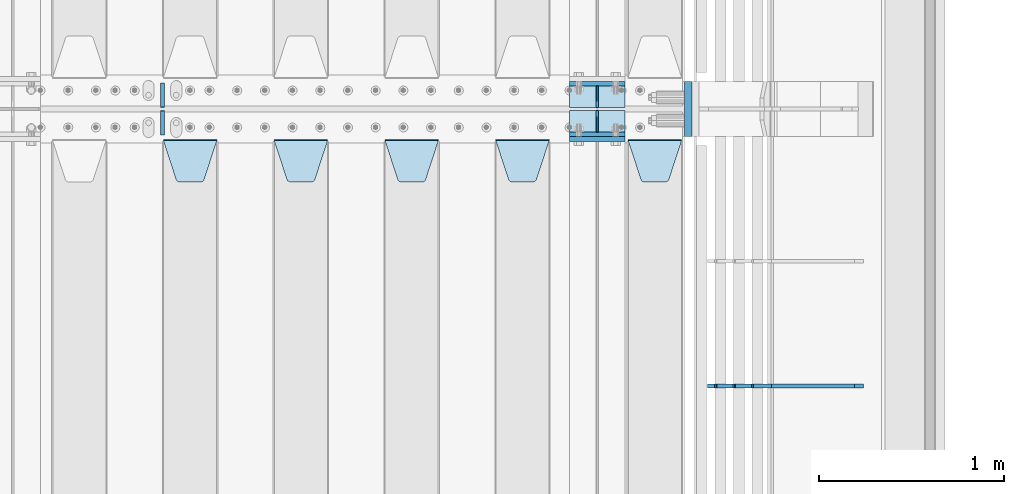
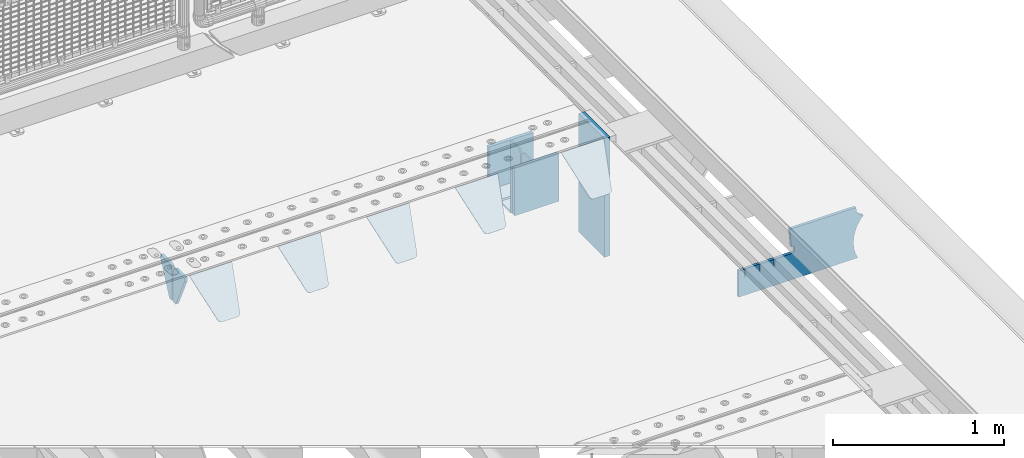
# One storey, part 220 of 240: 16 plates.
"""IFC2X3 building model written with IfcOpenShell, lengths in millimetres."""

from ifc_helpers import new_model, si_unit, frame, origin_with_axes, place, context, subcontext, project, spatial, faceted_brep, material, type_object, element, save


model = new_model("IFC2X3")

# Units and contexts
model_context = context("Model", 3, precision=1e-05, world=origin_with_axes())
body_context = subcontext(model_context, "Body", "Model", "MODEL_VIEW")
ifc_project = project(units=[si_unit("LENGTHUNIT", "METRE", prefix="MILLI"), si_unit("AREAUNIT", "SQUARE_METRE"), si_unit("VOLUMEUNIT", "CUBIC_METRE"), si_unit("MASSUNIT", "GRAM", prefix="KILO"), si_unit("TIMEUNIT", "SECOND"), si_unit("PLANEANGLEUNIT", "RADIAN"), si_unit("SOLIDANGLEUNIT", "STERADIAN"), si_unit("THERMODYNAMICTEMPERATUREUNIT", "DEGREE_CELSIUS"), si_unit("LUMINOUSINTENSITYUNIT", "LUMEN")], contexts=[model_context])

# Site, building, storey
site_placement = place(None, origin_with_axes())
site = spatial("IfcSite", under=ifc_project, at=site_placement, CompositionType="ELEMENT")
building_placement = place(site_placement, origin_with_axes())
building = spatial("IfcBuilding", under=site, at=building_placement, Name="Standard", CompositionType="ELEMENT")
storey_placement = place(building_placement, origin_with_axes())
storey = spatial("IfcBuildingStorey", under=building, at=storey_placement, Name="Undefined", CompositionType="ELEMENT", Elevation=0.0)

# Plates
ifc_material_1 = material(Name="STEEL/S355N")
plate_type_1 = type_object("IfcPlateType", PredefinedType="NOTDEFINED")
for number, where, z_axis, x_axis in (
    (1, (55855.0, 33137.5, -339.999999999995), (0.0, 0.0, 1.0), (1.0, 0.0, 0.0)),
    (2, (55855.0, 32862.5, -339.999999999995), (0.0, 0.0, 1.0), (1.0, 0.0, 0.0)),
):
    element("IfcPlate", number, at=place(storey_placement, frame(where, z_axis=z_axis, x_axis=x_axis)), inside=storey, type_object=plate_type_1, material=ifc_material_1, context=body_context, shape_type="Brep", body=[
        faceted_brep([(0.0, -12.5, 0.0), (0.0, -12.5, 310.0), (0.0, 12.5, 310.0), (0.0, 12.5, 0.0), (300.0, -12.5, 310.0), (300.0, 12.5, 310.0), (300.0, -12.5, 0.0), (300.0, 12.5, 0.0)], [[[0, 1, 2, 3]], [[1, 4, 5, 2]], [[4, 6, 7, 5]], [[6, 0, 3, 7]], [[5, 7, 3, 2]], [[6, 4, 1, 0]]]),
    ])
plate_1_placement = place(storey_placement, frame((55855.0, 32837.5, -340.000000000044), z_axis=(0.0, 0.0, 1.0), x_axis=(1.0, 0.0, 0.0)))
element("IfcPlate", 3, at=plate_1_placement, inside=storey, type_object=plate_type_1, material=ifc_material_1, context=body_context, shape_type="Brep", body=[
    faceted_brep([(0.0, -12.5, 0.0), (9.31322574615479e-10, -12.5, 340.0), (9.31322574615479e-10, 12.5, 340.0), (0.0, 12.5, 0.0), (300.0, -12.5, 340.0), (300.0, 12.5, 340.0), (300.0, -12.5, 0.0), (300.0, 12.5, 0.0)], [[[0, 1, 2, 3]], [[1, 4, 5, 2]], [[4, 6, 7, 5]], [[6, 0, 3, 7]], [[5, 7, 3, 2]], [[6, 4, 1, 0]]]),
])
plate_type_2 = type_object("IfcPlateType", PredefinedType="NOTDEFINED")
for number, where, z_axis, x_axis in (
    (4, (55855.0, 33008.0, -342.999999999995), (0.0, 1.0, 0.0), (1.0, 0.0, 0.0)),
    (5, (55855.0, 32992.0, -342.999999999995), (0.0, -1.0, 0.0), (1.0, 0.0, 0.0)),
):
    element("IfcPlate", number, at=place(storey_placement, frame(where, z_axis=z_axis, x_axis=x_axis)), inside=storey, type_object=plate_type_2, material=ifc_material_1, context=body_context, shape_type="Brep", body=[
        faceted_brep([(0.0, -7.0, 0.0), (0.0, -7.0, 117.0), (0.0, 7.0, 117.0), (0.0, 7.0, 0.0), (300.0, -7.0, 117.0), (300.0, 7.0, 117.0), (300.0, -7.0, 0.0), (300.0, 7.0, 0.0)], [[[0, 1, 2, 3]], [[1, 4, 5, 2]], [[4, 6, 7, 5]], [[6, 0, 3, 7]], [[5, 7, 3, 2]], [[6, 4, 1, 0]]]),
    ])
plate_type_3 = type_object("IfcPlateType", PredefinedType="NOTDEFINED")
for number, where, z_axis, x_axis in (
    (6, (56005.0, 33008.0, -29.9999999999945), (0.0, 0.0, -1.0), (0.0, 1.0, 0.0)),
    (7, (56005.0, 32992.0, -29.9999999999945), (0.0, 0.0, -1.0), (0.0, -1.0, 0.0)),
):
    element("IfcPlate", number, at=place(storey_placement, frame(where, z_axis=z_axis, x_axis=x_axis)), inside=storey, type_object=plate_type_3, material=ifc_material_1, context=body_context, shape_type="Brep", body=[
        faceted_brep([(0.0, -5.0, 30.0), (0.0, -5.0, 306.0), (0.0, 5.0, 306.0), (0.0, 5.0, 30.0), (117.0, -5.0, 306.0), (117.0, 5.0, 306.0), (117.0, -5.0, 0.0), (117.0, 5.0, 0.0), (30.0, -5.0, 0.0), (30.0, 5.0, 0.0), (24.7905546699913, -5.0, 0.455767409633758), (24.7905546699913, 5.0, 0.455767409633758), (19.7393957002278, -5.0, 1.80922137642275), (19.7393957002278, 5.0, 1.80922137642275), (15.0, -5.0, 4.01923788646684), (15.0, 5.0, 4.01923788646684), (10.7163717094008, -5.0, 7.01866670643066), (10.7163717094008, 5.0, 7.01866670643066), (7.01866670643358, -5.0, 10.7163717094038), (7.01866670643358, 5.0, 10.7163717094038), (4.01923788646673, -5.0, 15.0), (4.01923788646673, 5.0, 15.0), (1.80922137642483, -5.0, 19.7393957002299), (1.80922137642483, 5.0, 19.7393957002299), (0.455767409635882, -5.0, 24.7905546699921), (0.455767409635882, 5.0, 24.7905546699921)], [[[0, 1, 2, 3]], [[1, 4, 5, 2]], [[4, 6, 7, 5]], [[6, 8, 9, 7]], [[8, 10, 11, 9]], [[10, 12, 13, 11]], [[12, 14, 15, 13]], [[14, 16, 17, 15]], [[16, 18, 19, 17]], [[18, 20, 21, 19]], [[20, 22, 23, 21]], [[22, 24, 25, 23]], [[24, 0, 3, 25]], [[5, 7, 9, 11, 13, 15, 17, 19, 21, 23, 25, 3, 2]], [[24, 22, 20, 18, 16, 14, 12, 10, 8, 6, 4, 1, 0]]]),
    ])
plate_type_4 = type_object("IfcPlateType", PredefinedType="NOTDEFINED")
plate_2_placement = place(storey_placement, frame((56172.0, 32831.767766956, -1.76776695296758), z_axis=(0.0, -0.707106781186547, -0.707106781186548), x_axis=(1.0, 0.0, 0.0)))
element("IfcPlate", 8, at=plate_2_placement, inside=storey, type_object=plate_type_4, material=ifc_material_1, context=body_context, shape_type="Brep", body=[
    faceted_brep([(0.0, -2.5, 0.0), (69.345504679477, -2.50000000000364, 300.171731424827), (69.345504679477, 2.49999999999636, 300.171731424827), (0.0, 2.5, 0.0), (70.927406119954, -2.50000000000364, 304.897442415397), (70.927406119954, 2.49999999999636, 304.897442415397), (73.3818627772271, -2.50000000000728, 309.234538108525), (73.3818627772271, 2.49999999999636, 309.234538108529), (76.6187032999587, -2.50000000000728, 313.023683126099), (76.6187032999587, 2.49999999999636, 313.023683126103), (80.5190132705029, -2.50000000000364, 316.125672595368), (80.5190132705029, 2.49999999999636, 316.125672595368), (84.9395038596849, -2.50000000000364, 318.426546230472), (84.9395038596849, 2.49999999999636, 318.426546230472), (89.7177759439219, -2.5, 319.841774983277), (89.7177759439219, 2.49999999999636, 319.841774983273), (94.6782862926484, -2.50000000000364, 320.319366455074), (94.6782862926484, 2.49999999999636, 320.319366455074), (195.321713707352, -2.50000000000364, 320.319366455074), (195.321713707352, 2.49999999999636, 320.319366455074), (200.282224056078, -2.50000000000364, 319.841774983273), (200.282224056078, 2.49999999999636, 319.841774983273), (205.060496140315, -2.50000000000364, 318.426546230472), (205.060496140315, 2.49999999999636, 318.426546230472), (209.480986729497, -2.50000000000364, 316.125672595368), (209.480986729497, 2.49999999999636, 316.125672595368), (213.381296700041, -2.50000000000728, 313.023683126099), (213.381296700041, 2.49999999999272, 313.023683126099), (216.618137222766, -2.50000000000364, 309.234538108522), (216.618137222766, 2.49999999999636, 309.234538108522), (219.072593880039, -2.50000000000364, 304.897442415397), (219.072593880039, 2.49999999999636, 304.897442415397), (220.654495320523, -2.50000000000364, 300.171731424827), (220.654495320523, 2.49999999999636, 300.171731424827), (290.0, -2.50000000000364, -3.63797880709171e-12), (290.0, 2.49999999999636, -3.63797880709171e-12)], [[[0, 1, 2, 3]], [[1, 4, 5, 2]], [[4, 6, 7, 5]], [[6, 8, 9, 7]], [[8, 10, 11, 9]], [[10, 12, 13, 11]], [[12, 14, 15, 13]], [[14, 16, 17, 15]], [[16, 18, 19, 17]], [[18, 20, 21, 19]], [[20, 22, 23, 21]], [[22, 24, 25, 23]], [[24, 26, 27, 25]], [[26, 28, 29, 27]], [[28, 30, 31, 29]], [[30, 32, 33, 31]], [[32, 34, 35, 33]], [[34, 0, 3, 35]], [[5, 7, 9, 11, 13, 15, 17, 19, 21, 23, 25, 27, 29, 31, 33, 35, 3, 2]], [[34, 32, 30, 28, 26, 24, 22, 20, 18, 16, 14, 12, 10, 8, 6, 4, 1, 0]]]),
])
plate_3_placement = place(storey_placement, frame((55455.0, 32831.767766956, -1.76776695296758), z_axis=(0.0, -0.707106781186547, -0.707106781186548), x_axis=(1.0, 0.0, 0.0)))
element("IfcPlate", 9, at=plate_3_placement, inside=storey, type_object=plate_type_4, material=ifc_material_1, context=body_context, shape_type="Brep", body=[
    faceted_brep([(0.0, -2.5, 0.0), (69.345504679477, -2.50000000000364, 300.171731424827), (69.345504679477, 2.49999999999636, 300.171731424827), (0.0, 2.5, 0.0), (70.927406119954, -2.50000000000364, 304.897442415397), (70.927406119954, 2.49999999999636, 304.897442415397), (73.3818627772271, -2.50000000000728, 309.234538108525), (73.3818627772271, 2.49999999999636, 309.234538108529), (76.6187032999587, -2.50000000000728, 313.023683126099), (76.6187032999587, 2.49999999999636, 313.023683126103), (80.5190132705029, -2.50000000000364, 316.125672595368), (80.5190132705029, 2.49999999999636, 316.125672595368), (84.9395038596849, -2.50000000000364, 318.426546230472), (84.9395038596849, 2.49999999999636, 318.426546230472), (89.7177759439219, -2.5, 319.841774983277), (89.7177759439219, 2.49999999999636, 319.841774983273), (94.6782862926484, -2.50000000000364, 320.319366455074), (94.6782862926484, 2.49999999999636, 320.319366455074), (195.321713707352, -2.50000000000364, 320.319366455074), (195.321713707352, 2.49999999999636, 320.319366455074), (200.282224056078, -2.50000000000364, 319.841774983273), (200.282224056078, 2.49999999999636, 319.841774983273), (205.060496140315, -2.50000000000364, 318.426546230472), (205.060496140315, 2.49999999999636, 318.426546230472), (209.480986729497, -2.50000000000364, 316.125672595368), (209.480986729497, 2.49999999999636, 316.125672595368), (213.381296700041, -2.50000000000728, 313.023683126099), (213.381296700041, 2.49999999999272, 313.023683126099), (216.618137222766, -2.50000000000364, 309.234538108522), (216.618137222766, 2.49999999999636, 309.234538108522), (219.072593880039, -2.50000000000364, 304.897442415397), (219.072593880039, 2.49999999999636, 304.897442415397), (220.654495320523, -2.50000000000364, 300.171731424827), (220.654495320523, 2.49999999999636, 300.171731424827), (290.0, -2.50000000000364, -3.63797880709171e-12), (290.0, 2.49999999999636, -3.63797880709171e-12)], [[[0, 1, 2, 3]], [[1, 4, 5, 2]], [[4, 6, 7, 5]], [[6, 8, 9, 7]], [[8, 10, 11, 9]], [[10, 12, 13, 11]], [[12, 14, 15, 13]], [[14, 16, 17, 15]], [[16, 18, 19, 17]], [[18, 20, 21, 19]], [[20, 22, 23, 21]], [[22, 24, 25, 23]], [[24, 26, 27, 25]], [[26, 28, 29, 27]], [[28, 30, 31, 29]], [[30, 32, 33, 31]], [[32, 34, 35, 33]], [[34, 0, 3, 35]], [[5, 7, 9, 11, 13, 15, 17, 19, 21, 23, 25, 27, 29, 31, 33, 35, 3, 2]], [[34, 32, 30, 28, 26, 24, 22, 20, 18, 16, 14, 12, 10, 8, 6, 4, 1, 0]]]),
])
plate_4_placement = place(storey_placement, frame((54855.0, 32831.767766956, -1.76776695296758), z_axis=(0.0, -0.707106781186547, -0.707106781186548), x_axis=(1.0, 0.0, 0.0)))
element("IfcPlate", 10, at=plate_4_placement, inside=storey, type_object=plate_type_4, material=ifc_material_1, context=body_context, shape_type="Brep", body=[
    faceted_brep([(0.0, -2.5, 0.0), (69.345504679477, -2.50000000000364, 300.171731424827), (69.345504679477, 2.49999999999636, 300.171731424827), (0.0, 2.5, 0.0), (70.927406119954, -2.50000000000364, 304.897442415397), (70.927406119954, 2.49999999999636, 304.897442415397), (73.3818627772271, -2.50000000000728, 309.234538108525), (73.3818627772271, 2.49999999999636, 309.234538108529), (76.6187032999587, -2.50000000000728, 313.023683126099), (76.6187032999587, 2.49999999999636, 313.023683126103), (80.5190132705029, -2.50000000000364, 316.125672595368), (80.5190132705029, 2.49999999999636, 316.125672595368), (84.9395038596849, -2.50000000000364, 318.426546230472), (84.9395038596849, 2.49999999999636, 318.426546230472), (89.7177759439219, -2.5, 319.841774983277), (89.7177759439219, 2.49999999999636, 319.841774983273), (94.6782862926484, -2.50000000000364, 320.319366455074), (94.6782862926484, 2.49999999999636, 320.319366455074), (195.321713707352, -2.50000000000364, 320.319366455074), (195.321713707352, 2.49999999999636, 320.319366455074), (200.282224056078, -2.50000000000364, 319.841774983273), (200.282224056078, 2.49999999999636, 319.841774983273), (205.060496140315, -2.50000000000364, 318.426546230472), (205.060496140315, 2.49999999999636, 318.426546230472), (209.480986729497, -2.50000000000364, 316.125672595368), (209.480986729497, 2.49999999999636, 316.125672595368), (213.381296700041, -2.50000000000728, 313.023683126099), (213.381296700041, 2.49999999999272, 313.023683126099), (216.618137222766, -2.50000000000364, 309.234538108522), (216.618137222766, 2.49999999999636, 309.234538108522), (219.072593880039, -2.50000000000364, 304.897442415397), (219.072593880039, 2.49999999999636, 304.897442415397), (220.654495320523, -2.50000000000364, 300.171731424827), (220.654495320523, 2.49999999999636, 300.171731424827), (290.0, -2.50000000000364, -3.63797880709171e-12), (290.0, 2.49999999999636, -3.63797880709171e-12)], [[[0, 1, 2, 3]], [[1, 4, 5, 2]], [[4, 6, 7, 5]], [[6, 8, 9, 7]], [[8, 10, 11, 9]], [[10, 12, 13, 11]], [[12, 14, 15, 13]], [[14, 16, 17, 15]], [[16, 18, 19, 17]], [[18, 20, 21, 19]], [[20, 22, 23, 21]], [[22, 24, 25, 23]], [[24, 26, 27, 25]], [[26, 28, 29, 27]], [[28, 30, 31, 29]], [[30, 32, 33, 31]], [[32, 34, 35, 33]], [[34, 0, 3, 35]], [[5, 7, 9, 11, 13, 15, 17, 19, 21, 23, 25, 27, 29, 31, 33, 35, 3, 2]], [[34, 32, 30, 28, 26, 24, 22, 20, 18, 16, 14, 12, 10, 8, 6, 4, 1, 0]]]),
])
plate_5_placement = place(storey_placement, frame((54255.0, 32831.767766956, -1.76776695296758), z_axis=(0.0, -0.707106781186547, -0.707106781186548), x_axis=(1.0, 0.0, 0.0)))
element("IfcPlate", 11, at=plate_5_placement, inside=storey, type_object=plate_type_4, material=ifc_material_1, context=body_context, shape_type="Brep", body=[
    faceted_brep([(0.0, -2.5, 0.0), (69.345504679477, -2.50000000000364, 300.171731424827), (69.345504679477, 2.49999999999636, 300.171731424827), (0.0, 2.5, 0.0), (70.927406119954, -2.50000000000364, 304.897442415397), (70.927406119954, 2.49999999999636, 304.897442415397), (73.3818627772271, -2.50000000000728, 309.234538108525), (73.3818627772271, 2.49999999999636, 309.234538108529), (76.6187032999587, -2.50000000000728, 313.023683126099), (76.6187032999587, 2.49999999999636, 313.023683126103), (80.5190132705029, -2.50000000000364, 316.125672595368), (80.5190132705029, 2.49999999999636, 316.125672595368), (84.9395038596849, -2.50000000000364, 318.426546230472), (84.9395038596849, 2.49999999999636, 318.426546230472), (89.7177759439219, -2.5, 319.841774983277), (89.7177759439219, 2.49999999999636, 319.841774983273), (94.6782862926484, -2.50000000000364, 320.319366455074), (94.6782862926484, 2.49999999999636, 320.319366455074), (195.321713707352, -2.50000000000364, 320.319366455074), (195.321713707352, 2.49999999999636, 320.319366455074), (200.282224056078, -2.50000000000364, 319.841774983273), (200.282224056078, 2.49999999999636, 319.841774983273), (205.060496140315, -2.50000000000364, 318.426546230472), (205.060496140315, 2.49999999999636, 318.426546230472), (209.480986729497, -2.50000000000364, 316.125672595368), (209.480986729497, 2.49999999999636, 316.125672595368), (213.381296700041, -2.50000000000728, 313.023683126099), (213.381296700041, 2.49999999999272, 313.023683126099), (216.618137222766, -2.50000000000364, 309.234538108522), (216.618137222766, 2.49999999999636, 309.234538108522), (219.072593880039, -2.50000000000364, 304.897442415397), (219.072593880039, 2.49999999999636, 304.897442415397), (220.654495320523, -2.50000000000364, 300.171731424827), (220.654495320523, 2.49999999999636, 300.171731424827), (290.0, -2.50000000000364, -3.63797880709171e-12), (290.0, 2.49999999999636, -3.63797880709171e-12)], [[[0, 1, 2, 3]], [[1, 4, 5, 2]], [[4, 6, 7, 5]], [[6, 8, 9, 7]], [[8, 10, 11, 9]], [[10, 12, 13, 11]], [[12, 14, 15, 13]], [[14, 16, 17, 15]], [[16, 18, 19, 17]], [[18, 20, 21, 19]], [[20, 22, 23, 21]], [[22, 24, 25, 23]], [[24, 26, 27, 25]], [[26, 28, 29, 27]], [[28, 30, 31, 29]], [[30, 32, 33, 31]], [[32, 34, 35, 33]], [[34, 0, 3, 35]], [[5, 7, 9, 11, 13, 15, 17, 19, 21, 23, 25, 27, 29, 31, 33, 35, 3, 2]], [[34, 32, 30, 28, 26, 24, 22, 20, 18, 16, 14, 12, 10, 8, 6, 4, 1, 0]]]),
])
plate_6_placement = place(storey_placement, frame((53655.0, 32831.767766956, -1.76776695296758), z_axis=(0.0, -0.707106781186547, -0.707106781186548), x_axis=(1.0, 0.0, 0.0)))
element("IfcPlate", 12, at=plate_6_placement, inside=storey, type_object=plate_type_4, material=ifc_material_1, context=body_context, shape_type="Brep", body=[
    faceted_brep([(0.0, -2.5, 0.0), (69.345504679477, -2.50000000000364, 300.171731424827), (69.345504679477, 2.49999999999636, 300.171731424827), (0.0, 2.5, 0.0), (70.927406119954, -2.50000000000364, 304.897442415397), (70.927406119954, 2.49999999999636, 304.897442415397), (73.3818627772271, -2.50000000000728, 309.234538108525), (73.3818627772271, 2.49999999999636, 309.234538108529), (76.6187032999587, -2.50000000000728, 313.023683126099), (76.6187032999587, 2.49999999999636, 313.023683126103), (80.5190132705029, -2.50000000000364, 316.125672595368), (80.5190132705029, 2.49999999999636, 316.125672595368), (84.9395038596849, -2.50000000000364, 318.426546230472), (84.9395038596849, 2.49999999999636, 318.426546230472), (89.7177759439219, -2.5, 319.841774983277), (89.7177759439219, 2.49999999999636, 319.841774983273), (94.6782862926484, -2.50000000000364, 320.319366455074), (94.6782862926484, 2.49999999999636, 320.319366455074), (195.321713707352, -2.50000000000364, 320.319366455074), (195.321713707352, 2.49999999999636, 320.319366455074), (200.282224056078, -2.50000000000364, 319.841774983273), (200.282224056078, 2.49999999999636, 319.841774983273), (205.060496140315, -2.50000000000364, 318.426546230472), (205.060496140315, 2.49999999999636, 318.426546230472), (209.480986729497, -2.50000000000364, 316.125672595368), (209.480986729497, 2.49999999999636, 316.125672595368), (213.381296700041, -2.50000000000728, 313.023683126099), (213.381296700041, 2.49999999999272, 313.023683126099), (216.618137222766, -2.50000000000364, 309.234538108522), (216.618137222766, 2.49999999999636, 309.234538108522), (219.072593880039, -2.50000000000364, 304.897442415397), (219.072593880039, 2.49999999999636, 304.897442415397), (220.654495320523, -2.50000000000364, 300.171731424827), (220.654495320523, 2.49999999999636, 300.171731424827), (290.0, -2.50000000000364, -3.63797880709171e-12), (290.0, 2.49999999999636, -3.63797880709171e-12)], [[[0, 1, 2, 3]], [[1, 4, 5, 2]], [[4, 6, 7, 5]], [[6, 8, 9, 7]], [[8, 10, 11, 9]], [[10, 12, 13, 11]], [[12, 14, 15, 13]], [[14, 16, 17, 15]], [[16, 18, 19, 17]], [[18, 20, 21, 19]], [[20, 22, 23, 21]], [[22, 24, 25, 23]], [[24, 26, 27, 25]], [[26, 28, 29, 27]], [[28, 30, 31, 29]], [[30, 32, 33, 31]], [[32, 34, 35, 33]], [[34, 0, 3, 35]], [[5, 7, 9, 11, 13, 15, 17, 19, 21, 23, 25, 27, 29, 31, 33, 35, 3, 2]], [[34, 32, 30, 28, 26, 24, 22, 20, 18, 16, 14, 12, 10, 8, 6, 4, 1, 0]]]),
])
ifc_material_2 = material()
plate_type_5 = type_object("IfcPlateType", PredefinedType="NOTDEFINED")
plate_7_placement = place(storey_placement, frame((56497.0, 33150.0, -870.0), z_axis=(0.0, 0.0, 1.0), x_axis=(0.0, -1.0, 0.0)))
element("IfcPlate", 13, at=plate_7_placement, inside=storey, type_object=plate_type_5, material=ifc_material_2, context=body_context, shape_type="Brep", body=[
    faceted_brep([(0.0, -20.0, 0.0), (0.0, -20.0, 850.0), (0.0, 20.0, 850.0), (0.0, 20.0, 0.0), (300.0, -20.0, 850.0), (300.0, 20.0, 850.0), (300.0, -20.0, -1.81898940354586e-12), (300.0, 20.0, -1.81898940354586e-12)], [[[0, 1, 2, 3]], [[1, 4, 5, 2]], [[4, 6, 7, 5]], [[6, 0, 3, 7]], [[5, 7, 3, 2]], [[6, 4, 1, 0]]]),
])
plate_type_6 = type_object("IfcPlateType", PredefinedType="NOTDEFINED")
for number, where, z_axis, x_axis in (
    (14, (53650.0, 33140.0, -30.0), (0.0, 0.0, -1.0), (0.0, -1.0, 0.0)),
    (15, (53650.0, 32860.0, -30.0), (0.0, 0.0, -1.0), (0.0, 1.0, 0.0)),
):
    element("IfcPlate", number, at=place(storey_placement, frame(where, z_axis=z_axis, x_axis=x_axis)), inside=storey, type_object=plate_type_6, material=ifc_material_1, context=body_context, shape_type="Brep", body=[
        faceted_brep([(0.0, -10.0, 0.0), (0.0, -10.0, 30.0), (0.0, 10.0, 30.0), (0.0, 10.0, 0.0), (102.0, -10.0, 250.0), (102.0, 10.0, 250.0), (132.0, -10.0, 250.0), (132.0, 10.0, 250.0), (132.0, -10.0, 30.0), (132.0, 10.0, 30.0), (131.544232590368, -10.0, 24.790554669992), (131.544232590368, 10.0, 24.790554669992), (130.190778623579, -10.0, 19.7393957002299), (130.190778623579, 10.0, 19.7393957002299), (127.980762113533, -10.0, 15.0), (127.980762113533, 10.0, 15.0), (124.98133329357, -10.0, 10.7163717094038), (124.98133329357, 10.0, 10.7163717094038), (121.283628290596, -10.0, 7.01866670643062), (121.283628290596, 10.0, 7.01866670643062), (117.0, -10.0, 4.01923788646684), (117.0, 10.0, 4.01923788646684), (112.260604299769, -10.0, 1.80922137642278), (112.260604299769, 10.0, 1.80922137642278), (107.209445330009, -10.0, 0.455767409633722), (107.209445330009, 10.0, 0.455767409633722), (102.0, -10.0, 0.0), (102.0, 10.0, 0.0)], [[[0, 1, 2, 3]], [[1, 4, 5, 2]], [[4, 6, 7, 5]], [[6, 8, 9, 7]], [[8, 10, 11, 9]], [[10, 12, 13, 11]], [[12, 14, 15, 13]], [[14, 16, 17, 15]], [[16, 18, 19, 17]], [[18, 20, 21, 19]], [[20, 22, 23, 21]], [[22, 24, 25, 23]], [[24, 26, 27, 25]], [[26, 0, 3, 27]], [[5, 7, 9, 11, 13, 15, 17, 19, 21, 23, 25, 27, 3, 2]], [[26, 24, 22, 20, 18, 16, 14, 12, 10, 8, 6, 4, 1, 0]]]),
    ])
plate_type_7 = type_object("IfcPlateType", PredefinedType="NOTDEFINED")
plate_8_placement = place(storey_placement, frame((57442.9182339676, 31499.9992828369, -374.002067436517), z_axis=(0.0, 0.0, 1.0), x_axis=(-1.0, 0.0, 0.0)))
element("IfcPlate", 16, at=plate_8_placement, inside=storey, type_object=plate_type_7, material=ifc_material_1, context=body_context, shape_type="Brep", body=[
    faceted_brep([(801.919404066546, -10.0, 188.0), (801.919404066546, 10.0, 188.0), (801.919404066546, 10.0, 132.002067436952), (801.919404066546, -10.0, 132.002067436952), (793.919404066546, 10.0, 132.002067436952), (793.919404066546, -10.0, 132.002067436952), (793.919404066546, 10.0, 180.002067436952), (793.919404066546, -10.0, 180.002067436952), (793.52785619691, 10.0, 182.474203391951), (793.52785619691, -10.0, 182.474203391951), (792.391540021548, 10.0, 184.704349455291), (792.391540021548, -10.0, 184.704349455291), (790.621686084887, 10.0, 186.474203391951), (790.621686084887, -10.0, 186.474203391951), (788.391540021548, 10.0, 187.610519567313), (788.391540021548, -10.0, 187.610519567313), (785.919404066546, -10.0, 188.002067436952), (785.919404066546, 10.0, 188.0), (841.0, -10.0, 188.0), (841.0, -10.0, 0.0), (841.0, 10.0, 0.0), (841.0, 10.0, 188.0), (33.3619566735943, -10.0, 0.0), (33.3619566735943, 10.0, 0.0), (36.2350612208102, -10.0, 4.68848050267013), (36.2350612208102, 10.0, 4.68848050267013), (51.4877592159319, -10.0, 41.5117508652784), (51.4877592159319, 10.0, 41.5117508652784), (60.7922425881334, -10.0, 80.2677133162964), (60.7922425881334, 10.0, 80.2677133162964), (63.9194040769653, -10.0, 120.002067436515), (63.9194040769653, 10.0, 120.002067436515), (60.7922425881334, -10.0, 159.736421556734), (60.7922425881334, 10.0, 159.736421556734), (51.4877592159319, -10.0, 198.492384007752), (51.4877592159319, 10.0, 198.492384007752), (36.2350612208102, -10.0, 235.31565437036), (36.2350612208102, 10.0, 235.31565437036), (15.4097206482038, -10.0, 269.299521518803), (15.4097206482038, 10.0, 269.299521518803), (-3.35474438100209, -10.0, 291.269887256574), (-3.35474438100209, 10.0, 291.269887256574), (-2.36881039375294, -10.0000000000036, 291.426043859339), (-2.36881039375294, 10.0, 291.426043859339), (17.1449676604752, -10.0000000000036, 301.368810393754), (17.1449676604752, 10.0, 301.368810393754), (32.6311896062471, -10.0000000000036, 316.855032339527), (32.6311896062471, 10.0, 316.855032339527), (42.573956140659, -10.0000000000036, 336.368810393754), (42.573956140659, 10.0, 336.368810393754), (46.0, -10.0000000000036, 358.0), (46.0, 10.0, 358.0), (45.0495205499246, -10.0, 364.001091067617), (45.0495205499246, 10.0, 364.001091067617), (495.040008544922, -10.0, 364.010009765625), (495.040008544922, 10.0, 364.010009765625), (483.600036621094, -10.0, 233.759994506836), (483.600036621094, 10.0, 233.759994506836), (472.0, -10.0, 233.759994506836), (472.0, 10.0, 233.759994506836), (468.909830056247, -10.0, 233.270559669787), (468.909830056247, 10.0, 233.270559669787), (466.122147477072, -10.0, 231.850164450585), (466.122147477072, 10.0, 231.850164450585), (463.909830056247, -10.0, 229.637847029761), (463.909830056247, 10.0, 229.637847029761), (462.489434837051, -10.0, 226.850164450585), (462.489434837051, 10.0, 226.850164450585), (462.0, -10.0, 223.759994506836), (462.0, 10.0, 223.759994506836), (462.0, -10.0, 198.0), (462.0, 10.0, 198.0), (462.489434837051, -10.0, 194.909830056251), (462.489434837051, 10.0, 194.909830056251), (463.909830056247, -10.0, 192.122147477075), (463.909830056247, 10.0, 192.122147477075), (466.122147477072, -10.0, 189.909830056251), (466.122147477072, 10.0, 189.909830056251), (468.909830056247, -10.0, 188.489434837048), (468.909830056247, 10.0, 188.489434837048), (472.0, -10.0, 188.0), (472.0, 10.0, 188.0), (585.919404066546, -10.0, 188.002067436952), (585.919404066546, 10.0, 188.0), (588.391540021548, -9.99999999999636, 187.610519567313), (588.391540021548, 10.0, 187.610519567313), (590.621686084887, -9.99999999999636, 186.474203391951), (590.621686084887, 10.0, 186.474203391951), (592.391540021548, -9.99999999999636, 184.704349455291), (592.391540021548, 10.0, 184.704349455291), (593.52785619691, -9.99999999999636, 182.474203391951), (593.52785619691, 10.0, 182.474203391951), (593.919404066546, -9.99999999999636, 180.002067436952), (593.919404066546, 10.0, 180.002067436952), (593.919404066546, -9.99999999999636, 132.002067436952), (593.919404066546, 10.0, 132.002067436952), (601.919404066546, -9.99999999999636, 132.002067436952), (601.919404066546, 10.0, 132.002067436952), (601.919404066546, -10.0, 188.0), (601.919404066546, 10.0, 188.0), (685.919404066546, -10.0, 188.002067436952), (685.919404066546, 10.0, 188.0), (688.391540021548, -10.0, 187.610519567313), (688.391540021548, 10.0, 187.610519567313), (690.621686084887, -10.0, 186.474203391951), (690.621686084887, 10.0, 186.474203391951), (692.391540021548, -10.0, 184.704349455291), (692.391540021548, 10.0, 184.704349455291), (693.52785619691, -10.0, 182.474203391951), (693.52785619691, 10.0, 182.474203391951), (693.919404066546, -10.0, 180.002067436952), (693.919404066546, 10.0, 180.002067436952), (693.919404066546, -10.0, 132.002067436952), (693.919404066546, 10.0000000000036, 132.002067436952), (701.919404066546, -10.0, 132.002067436952), (701.919404066546, 10.0000000000036, 132.002067436952), (701.919404066546, -10.0, 188.0), (701.919404066546, 10.0, 188.0)], [[[0, 1, 2, 3]], [[3, 2, 4, 5]], [[5, 4, 6, 7]], [[7, 6, 8, 9]], [[9, 8, 10, 11]], [[11, 10, 12, 13]], [[13, 12, 14, 15]], [[16, 15, 14, 17]], [[18, 19, 20, 21]], [[20, 19, 22, 23]], [[22, 24, 25, 23]], [[26, 27, 25, 24]], [[28, 29, 27, 26]], [[30, 31, 29, 28]], [[32, 33, 31, 30]], [[34, 35, 33, 32]], [[36, 37, 35, 34]], [[38, 39, 37, 36]], [[39, 38, 40, 41]], [[40, 42, 43, 41]], [[44, 45, 43, 42]], [[46, 47, 45, 44]], [[48, 49, 47, 46]], [[50, 51, 49, 48]], [[52, 53, 51, 50]], [[54, 55, 53, 52]], [[54, 56, 57, 55]], [[56, 58, 59, 57]], [[58, 60, 61, 59]], [[60, 62, 63, 61]], [[62, 64, 65, 63]], [[64, 66, 67, 65]], [[66, 68, 69, 67]], [[68, 70, 71, 69]], [[70, 72, 73, 71]], [[72, 74, 75, 73]], [[74, 76, 77, 75]], [[76, 78, 79, 77]], [[78, 80, 81, 79]], [[81, 80, 82, 83]], [[82, 84, 85, 83]], [[86, 87, 85, 84]], [[88, 89, 87, 86]], [[90, 91, 89, 88]], [[92, 93, 91, 90]], [[94, 95, 93, 92]], [[96, 97, 95, 94]], [[98, 99, 97, 96]], [[99, 98, 100, 101]], [[100, 102, 103, 101]], [[104, 105, 103, 102]], [[106, 107, 105, 104]], [[108, 109, 107, 106]], [[110, 111, 109, 108]], [[112, 113, 111, 110]], [[114, 115, 113, 112]], [[116, 117, 115, 114]], [[117, 116, 16, 17]], [[12, 10, 8, 6, 4, 2, 1, 21, 20, 23, 25, 27, 29, 31, 33, 35, 37, 39, 41, 43, 45, 47, 49, 51, 53, 55, 57, 59, 61, 63, 65, 67, 69, 71, 73, 75, 77, 79, 81, 83, 85, 87, 89, 91, 93, 95, 97, 99, 101, 103, 105, 107, 109, 111, 113, 115, 117, 17, 14]], [[18, 21, 1, 0]], [[116, 114, 112, 110, 108, 106, 104, 102, 100, 98, 96, 94, 92, 90, 88, 86, 84, 82, 80, 78, 76, 74, 72, 70, 68, 66, 64, 62, 60, 58, 56, 54, 52, 50, 48, 46, 44, 42, 40, 38, 36, 34, 32, 30, 28, 26, 24, 22, 19, 18, 0, 3, 5, 7, 9, 11, 13, 15, 16]]]),
])

save(model, "model.ifc")
